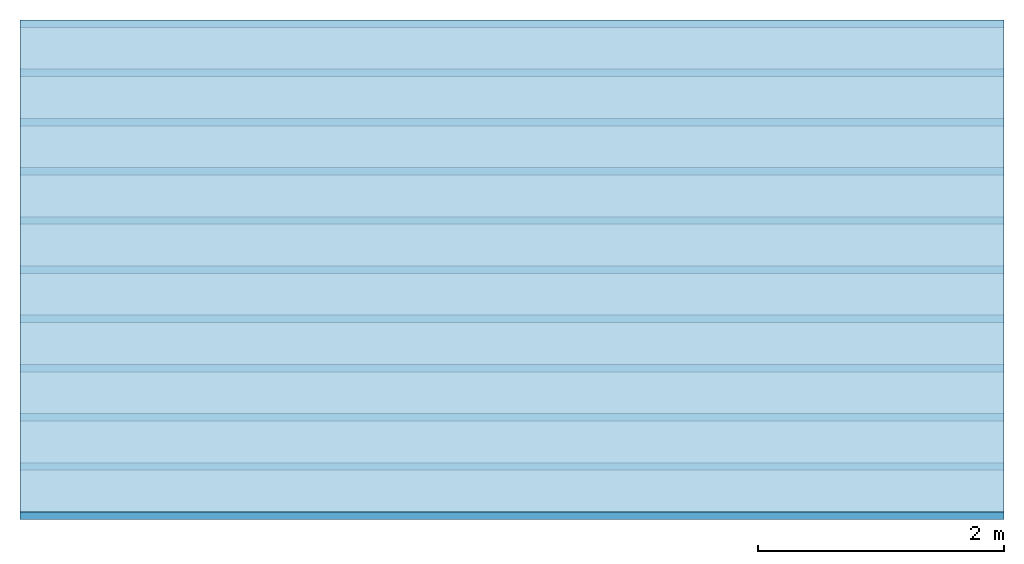
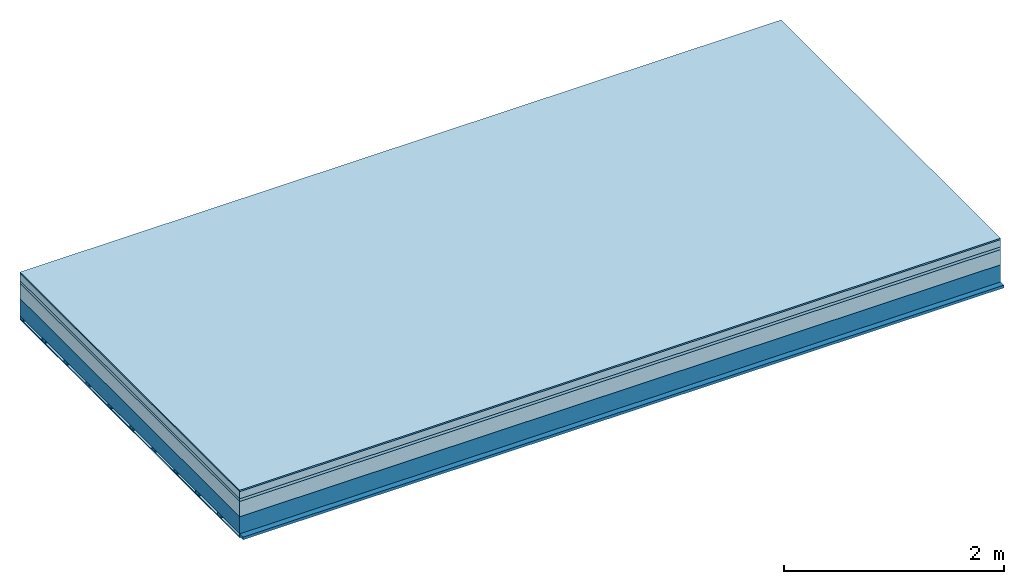
# One storey: 6 plates, 2 members, 1 element without a shape of its own.
"""IFC4 building model written with IfcOpenShell, lengths in metres."""

from ifc_helpers import new_model, si_unit, derived_unit, direction, frame, frame_2d, origin, origin_with_axes, place, context, project, spatial, rectangle, extrude, material, layer, layer_set, type_object, element, aggregate, save


model = new_model("IFC4")

# Units and contexts
plan_context = context("Plan", 3, precision=1e-05, world=origin(), true_north=direction((0.0, 1.0)))
model_context = context("Model", 3, precision=1e-05, world=origin(), true_north=direction((0.0, 1.0)))
ifc_project = project(units=[si_unit("LENGTHUNIT", "METRE"), derived_unit("SOUNDPRESSUREUNIT", [(si_unit("PRESSUREUNIT", "PASCAL", prefix="MICRO"), 0)]), si_unit("ENERGYUNIT", "JOULE", prefix="MEGA"), si_unit("MASSUNIT", "GRAM", prefix="KILO"), derived_unit("THERMALTRANSMITTANCEUNIT", [(si_unit("POWERUNIT", "WATT"), 1), (si_unit("AREAUNIT", "SQUARE_METRE"), -1), (si_unit("THERMODYNAMICTEMPERATUREUNIT", "KELVIN"), -1)]), derived_unit("AREADENSITYUNIT", [(si_unit("MASSUNIT", "GRAM", prefix="KILO"), 1), (si_unit("AREAUNIT", "SQUARE_METRE"), -1)]), derived_unit("USERDEFINED", [(si_unit("ENERGYUNIT", "JOULE", prefix="MEGA"), 1), (si_unit("AREAUNIT", "SQUARE_METRE"), -1)])], contexts=[plan_context, model_context])

# Site, building, storey
site = spatial("IfcSite", under=ifc_project)
building_placement = place(None, origin())
building = spatial("IfcBuilding", under=site, at=building_placement)
storey_placement = place(building_placement, origin())
storey = spatial("IfcBuildingStorey", under=building, at=storey_placement)

# Slab, members, plates
ifc_material_1 = material(Category="11.013")
ifc_layer_1 = layer(ifc_material_1, 0.015, Name="Flooring")
ifc_material_2 = material(Name="Cement screed", Category="04.006")
ifc_layer_2 = layer(ifc_material_2, 0.08, Name="On-material")
ifc_material_3 = material(Name="Wood fiber generic product", Category="10.009")
ifc_layer_3 = layer(ifc_material_3, 0.03, Name="Impact sound insulation")
ifc_material_4 = material(Category="01.002")
ifc_layer_4 = layer(ifc_material_4, 0.17, Name="Sub-floor")
ifc_material_5 = material(Name="Rigid, of the art")
ifc_layer_5 = layer(ifc_material_5, 0.0, Name="Bond")
ifc_layer_6 = layer(None, 0.19, Name="Supporting structure")
ifc_material_6 = material(Name="of the art")
ifc_layer_7 = layer(ifc_material_6, 0.0, Name="Bond")
ifc_layer_8 = layer(None, 0.03, Name="Battens / profiles")
ifc_material_7 = material(Name="Plasterboard type A", Category="03.008")
ifc_layer_9 = layer(ifc_material_7, 0.0125, Name="Ceiling covering 1st layer")
ifc_material_8 = material(Category="04.001")
ifc_layer_10 = layer(ifc_material_8, 0.003, Name="Surface / treatment")
ifc_layer_set = layer_set([ifc_layer_1, ifc_layer_2, ifc_layer_3, ifc_layer_4, ifc_layer_5, ifc_layer_6, ifc_layer_7, ifc_layer_8, ifc_layer_9, ifc_layer_10])
slab_type = type_object("IfcSlabType", Name="A2229", PredefinedType="NOTDEFINED", material=ifc_layer_set)
slab_placement = place(None, frame((0.0, 0.0, 0.0), z_axis=(0.0, 0.0, -1.0), x_axis=(1.0, 0.0, 0.0)))
slab = element("IfcSlab", 1, at=slab_placement, inside=storey, type_object=slab_type, material=ifc_layer_set, Name="Slab #1")
ifc_material_9 = material(Name="Solid timber panel")
member_1_placement = place(slab_placement, origin())
member_1 = element("IfcMember", 2, at=member_1_placement, material=ifc_material_9, Name="Supporting structure", context=plan_context, shape_type="SweptSolid", body=[
    extrude(rectangle(XDim=1.0, YDim=0.19, at=frame_2d((0.5, 0.095), x_axis=(1.0, 0.0))), frame((0.0, 4.0, 0.295), z_axis=(0.0, -1.0, 0.0), x_axis=(1.0, 0.0, 0.0)), (0.0, 0.0, 1.0), 4.0),
    extrude(rectangle(XDim=1.0, YDim=0.19, at=frame_2d((0.5, 0.095), x_axis=(1.0, 0.0))), frame((1.0, 4.0, 0.295), z_axis=(0.0, -1.0, 0.0), x_axis=(1.0, 0.0, 0.0)), (0.0, 0.0, 1.0), 4.0),
    extrude(rectangle(XDim=1.0, YDim=0.19, at=frame_2d((0.5, 0.095), x_axis=(1.0, 0.0))), frame((2.0, 4.0, 0.295), z_axis=(0.0, -1.0, 0.0), x_axis=(1.0, 0.0, 0.0)), (0.0, 0.0, 1.0), 4.0),
    extrude(rectangle(XDim=1.0, YDim=0.19, at=frame_2d((0.5, 0.095), x_axis=(1.0, 0.0))), frame((3.0, 4.0, 0.295), z_axis=(0.0, -1.0, 0.0), x_axis=(1.0, 0.0, 0.0)), (0.0, 0.0, 1.0), 4.0),
    extrude(rectangle(XDim=1.0, YDim=0.19, at=frame_2d((0.5, 0.095), x_axis=(1.0, 0.0))), frame((4.0, 4.0, 0.295), z_axis=(0.0, -1.0, 0.0), x_axis=(1.0, 0.0, 0.0)), (0.0, 0.0, 1.0), 4.0),
    extrude(rectangle(XDim=1.0, YDim=0.19, at=frame_2d((0.5, 0.095), x_axis=(1.0, 0.0))), frame((5.0, 4.0, 0.295), z_axis=(0.0, -1.0, 0.0), x_axis=(1.0, 0.0, 0.0)), (0.0, 0.0, 1.0), 4.0),
    extrude(rectangle(XDim=1.0, YDim=0.19, at=frame_2d((0.5, 0.095), x_axis=(1.0, 0.0))), frame((6.0, 4.0, 0.295), z_axis=(0.0, -1.0, 0.0), x_axis=(1.0, 0.0, 0.0)), (0.0, 0.0, 1.0), 4.0),
    extrude(rectangle(XDim=1.0, YDim=0.19, at=frame_2d((0.5, 0.095), x_axis=(1.0, 0.0))), frame((7.0, 4.0, 0.295), z_axis=(0.0, -1.0, 0.0), x_axis=(1.0, 0.0, 0.0)), (0.0, 0.0, 1.0), 4.0),
])
ifc_material_10 = material()
member_2_placement = place(slab_placement, origin())
member_2 = element("IfcMember", 3, at=member_2_placement, material=ifc_material_10, Name="Battens / profiles", context=plan_context, shape_type="SweptSolid", body=[
    extrude(rectangle(XDim=0.06, YDim=0.03, at=frame_2d((0.03, 0.015), x_axis=(1.0, 0.0))), frame((0.0, 0.0, 0.485), z_axis=(1.0, 0.0, 0.0), x_axis=(0.0, 1.0, 0.0)), (0.0, 0.0, 1.0), 8.0),
    extrude(rectangle(XDim=0.06, YDim=0.03, at=frame_2d((0.03, 0.015), x_axis=(1.0, 0.0))), frame((0.0, 0.4, 0.485), z_axis=(1.0, 0.0, 0.0), x_axis=(0.0, 1.0, 0.0)), (0.0, 0.0, 1.0), 8.0),
    extrude(rectangle(XDim=0.06, YDim=0.03, at=frame_2d((0.03, 0.015), x_axis=(1.0, 0.0))), frame((0.0, 0.8, 0.485), z_axis=(1.0, 0.0, 0.0), x_axis=(0.0, 1.0, 0.0)), (0.0, 0.0, 1.0), 8.0),
    extrude(rectangle(XDim=0.06, YDim=0.03, at=frame_2d((0.03, 0.015), x_axis=(1.0, 0.0))), frame((0.0, 1.2, 0.485), z_axis=(1.0, 0.0, 0.0), x_axis=(0.0, 1.0, 0.0)), (0.0, 0.0, 1.0), 8.0),
    extrude(rectangle(XDim=0.06, YDim=0.03, at=frame_2d((0.03, 0.015), x_axis=(1.0, 0.0))), frame((0.0, 1.6, 0.485), z_axis=(1.0, 0.0, 0.0), x_axis=(0.0, 1.0, 0.0)), (0.0, 0.0, 1.0), 8.0),
    extrude(rectangle(XDim=0.06, YDim=0.03, at=frame_2d((0.03, 0.015), x_axis=(1.0, 0.0))), frame((0.0, 2.0, 0.485), z_axis=(1.0, 0.0, 0.0), x_axis=(0.0, 1.0, 0.0)), (0.0, 0.0, 1.0), 8.0),
    extrude(rectangle(XDim=0.06, YDim=0.03, at=frame_2d((0.03, 0.015), x_axis=(1.0, 0.0))), frame((0.0, 2.4, 0.485), z_axis=(1.0, 0.0, 0.0), x_axis=(0.0, 1.0, 0.0)), (0.0, 0.0, 1.0), 8.0),
    extrude(rectangle(XDim=0.06, YDim=0.03, at=frame_2d((0.03, 0.015), x_axis=(1.0, 0.0))), frame((0.0, 2.8, 0.485), z_axis=(1.0, 0.0, 0.0), x_axis=(0.0, 1.0, 0.0)), (0.0, 0.0, 1.0), 8.0),
    extrude(rectangle(XDim=0.06, YDim=0.03, at=frame_2d((0.03, 0.015), x_axis=(1.0, 0.0))), frame((0.0, 3.2, 0.485), z_axis=(1.0, 0.0, 0.0), x_axis=(0.0, 1.0, 0.0)), (0.0, 0.0, 1.0), 8.0),
    extrude(rectangle(XDim=0.06, YDim=0.03, at=frame_2d((0.03, 0.015), x_axis=(1.0, 0.0))), frame((0.0, 3.6, 0.485), z_axis=(1.0, 0.0, 0.0), x_axis=(0.0, 1.0, 0.0)), (0.0, 0.0, 1.0), 8.0),
    extrude(rectangle(XDim=0.06, YDim=0.03, at=frame_2d((0.03, 0.015), x_axis=(1.0, 0.0))), frame((0.0, 4.0, 0.485), z_axis=(1.0, 0.0, 0.0), x_axis=(0.0, 1.0, 0.0)), (0.0, 0.0, 1.0), 8.0),
])
plate_1_placement = place(slab_placement, origin())
plate_1 = element("IfcPlate", 4, at=plate_1_placement, material=ifc_material_1, Name="Flooring", context=plan_context, shape_type="SweptSolid", body=[
    extrude(rectangle(XDim=8.0, YDim=4.0, at=frame_2d((4.0, 2.0), x_axis=(1.0, 0.0))), origin_with_axes(), (0.0, 0.0, 1.0), 0.015),
])
plate_2_placement = place(slab_placement, origin())
plate_2 = element("IfcPlate", 5, at=plate_2_placement, material=ifc_material_2, Name="On-material", context=plan_context, shape_type="SweptSolid", body=[
    extrude(rectangle(XDim=8.0, YDim=4.0, at=frame_2d((4.0, 2.0), x_axis=(1.0, 0.0))), frame((0.0, 0.0, 0.015), z_axis=(0.0, 0.0, 1.0), x_axis=(1.0, 0.0, 0.0)), (0.0, 0.0, 1.0), 0.08),
])
plate_3_placement = place(slab_placement, origin())
plate_3 = element("IfcPlate", 6, at=plate_3_placement, material=ifc_material_3, Name="Impact sound insulation", context=plan_context, shape_type="SweptSolid", body=[
    extrude(rectangle(XDim=8.0, YDim=4.0, at=frame_2d((4.0, 2.0), x_axis=(1.0, 0.0))), frame((0.0, 0.0, 0.095), z_axis=(0.0, 0.0, 1.0), x_axis=(1.0, 0.0, 0.0)), (0.0, 0.0, 1.0), 0.03),
])
plate_4_placement = place(slab_placement, origin())
plate_4 = element("IfcPlate", 7, at=plate_4_placement, material=ifc_material_4, Name="Sub-floor", context=plan_context, shape_type="SweptSolid", body=[
    extrude(rectangle(XDim=8.0, YDim=4.0, at=frame_2d((4.0, 2.0), x_axis=(1.0, 0.0))), frame((0.0, 0.0, 0.125), z_axis=(0.0, 0.0, 1.0), x_axis=(1.0, 0.0, 0.0)), (0.0, 0.0, 1.0), 0.17),
])
plate_5_placement = place(slab_placement, origin())
plate_5 = element("IfcPlate", 8, at=plate_5_placement, material=ifc_material_7, Name="Ceiling covering 1st layer", context=plan_context, shape_type="SweptSolid", body=[
    extrude(rectangle(XDim=8.0, YDim=4.0, at=frame_2d((4.0, 2.0), x_axis=(1.0, 0.0))), frame((0.0, 0.0, 0.515), z_axis=(0.0, 0.0, 1.0), x_axis=(1.0, 0.0, 0.0)), (0.0, 0.0, 1.0), 0.0125),
])
plate_6_placement = place(slab_placement, origin())
plate_6 = element("IfcPlate", 9, at=plate_6_placement, material=ifc_material_8, Name="Surface / treatment", context=plan_context, shape_type="SweptSolid", body=[
    extrude(rectangle(XDim=8.0, YDim=4.0, at=frame_2d((4.0, 2.0), x_axis=(1.0, 0.0))), frame((0.0, 0.0, 0.5275), z_axis=(0.0, 0.0, 1.0), x_axis=(1.0, 0.0, 0.0)), (0.0, 0.0, 1.0), 0.003),
])
aggregate(slab, [plate_1, plate_2, plate_3, plate_4, member_1, member_2, plate_5, plate_6])

save(model, "model.ifc")
